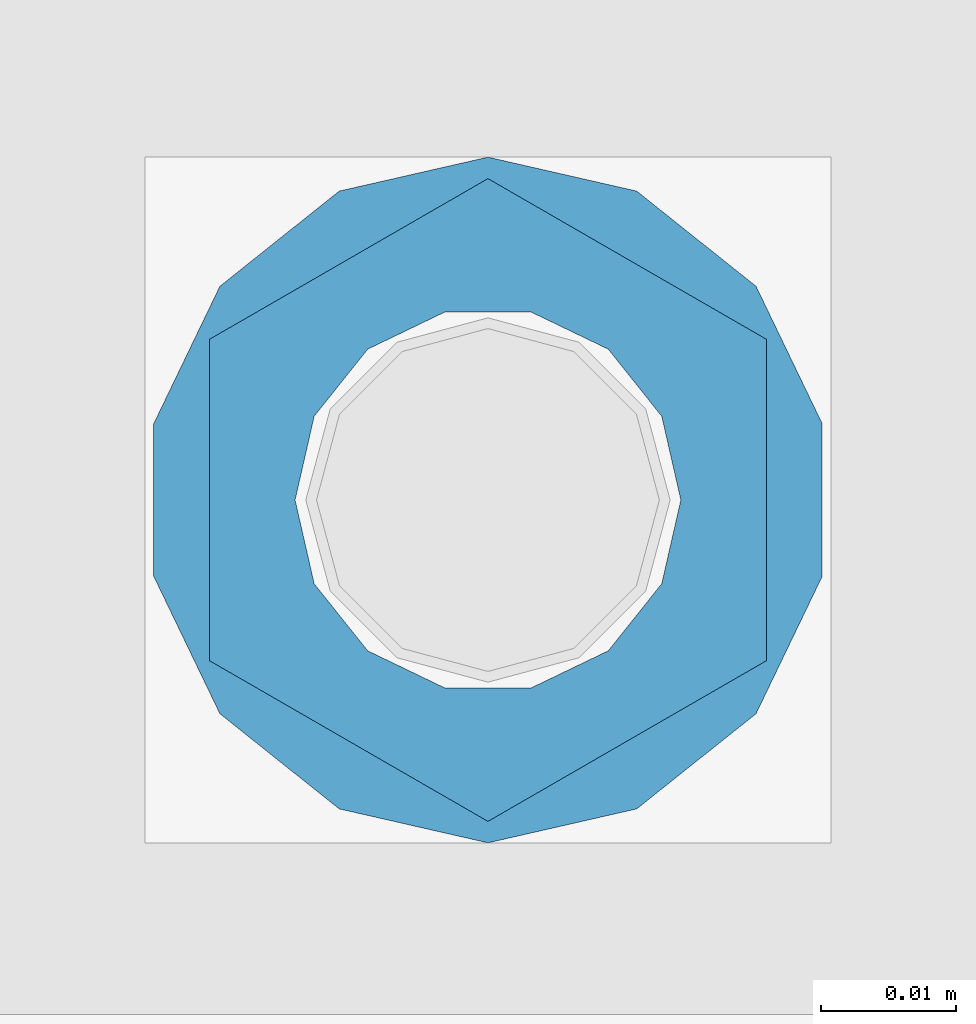
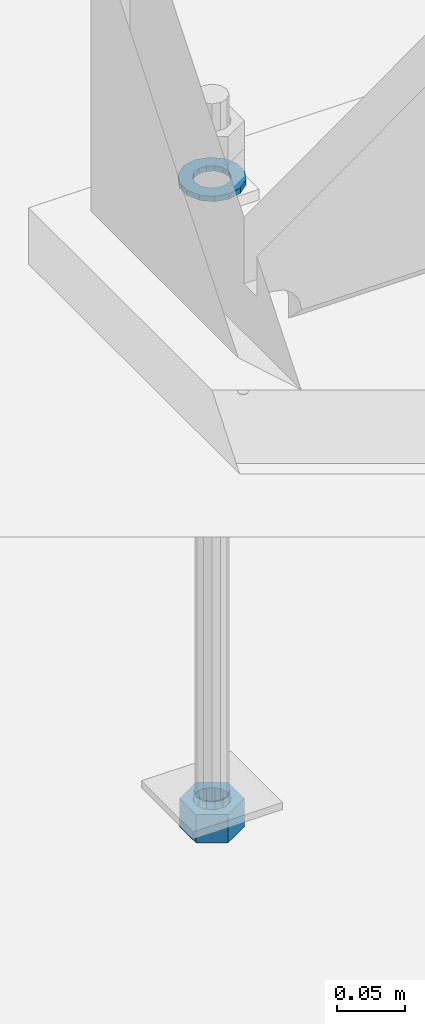
# One storey, part 1021 of 1763: 2 columns, 1 element without a shape of its own.
"""IFC2X3 building model written with IfcOpenShell, lengths in millimetres."""

from ifc_helpers import new_model, si_unit, frame, origin_with_axes, place, context, subcontext, project, spatial, faceted_brep, material, type_object, element, aggregate, save


model = new_model("IFC2X3")

# Units and contexts
model_context = context("Model", 3, precision=1e-05, world=origin_with_axes())
body_context = subcontext(model_context, "Body", "Model", "MODEL_VIEW")
ifc_project = project(units=[si_unit("LENGTHUNIT", "METRE", prefix="MILLI"), si_unit("AREAUNIT", "SQUARE_METRE"), si_unit("VOLUMEUNIT", "CUBIC_METRE"), si_unit("MASSUNIT", "GRAM", prefix="KILO"), si_unit("TIMEUNIT", "SECOND"), si_unit("PLANEANGLEUNIT", "RADIAN"), si_unit("SOLIDANGLEUNIT", "STERADIAN"), si_unit("THERMODYNAMICTEMPERATUREUNIT", "DEGREE_CELSIUS"), si_unit("LUMINOUSINTENSITYUNIT", "LUMEN")], contexts=[model_context])

# Site, building, storey
site_placement = place(None, origin_with_axes())
site = spatial("IfcSite", under=ifc_project, at=site_placement, CompositionType="ELEMENT")
building_placement = place(site_placement, origin_with_axes())
building = spatial("IfcBuilding", under=site, at=building_placement, Name="Undefined", CompositionType="ELEMENT")
storey_placement = place(building_placement, origin_with_axes())
storey = spatial("IfcBuildingStorey", under=building, at=storey_placement, Name="Undefined", CompositionType="ELEMENT", Elevation=0.0)

# Assembly, columns
assembly_placement = place(storey_placement, origin_with_axes())
assembly = element("IfcElementAssembly", 1, at=assembly_placement, inside=storey, Name="TEMPLATE", AssemblyPlace="NOTDEFINED", PredefinedType="RIGID_FRAME")
ifc_material_1 = material(Name="STEEL/A563")
column_type_1 = type_object("IfcColumnType", Name="1_HEAVY_HEX_NUT", PredefinedType="NOTDEFINED")
column_1_placement = place(assembly_placement, frame((-72745.0372736984, 52298.6, -761.999999999999), z_axis=(-1.0, 0.0, 0.0), x_axis=(0.0, 0.0, -1.0)))
column_1 = element("IfcColumn", 2, at=column_1_placement, type_object=column_type_1, material=ifc_material_1, Name="NUT", ObjectType="1_HEAVY_HEX_NUT", context=body_context, shape_type="Brep", body=[
    faceted_brep([(0.0, -23.8099994659424, 0.0), (0.0, -11.9099998474121, -20.6200008392334), (25.4, -11.9099998474121, -20.6200008392334), (25.4, -23.8099994659424, 0.0), (0.0, 11.9099998474121, -20.6200008392334), (25.4, 11.9099998474121, -20.6200008392334), (0.0, 23.8099994659424, 0.0), (25.4, 23.8099994659424, 0.0), (0.0, 11.9099998474121, 20.6200008392334), (25.4, 11.9099998474121, 20.6200008392334), (0.0, -11.9099998474121, 20.6200008392334), (25.4, -11.9099998474121, 20.6200008392334), (0.0, 0.0, 14.289999961853), (0.0, 6.20019861543551, 12.8748450879575), (25.4, 6.20019861543551, 12.8748450879502), (25.4, 0.0, 14.289999961853), (0.0, 11.1723718546418, 8.90966924477834), (25.4, 11.1723718546418, 8.90966924477834), (0.0, 13.9317198278877, 3.17982413774735), (25.4, 13.9317198278877, 3.17982413774007), (0.0, 13.9317198278877, -3.17982413774735), (25.4, 13.9317198278877, -3.17982413774007), (0.0, 11.1723718546418, -8.90966924477834), (25.4, 11.1723718546418, -8.90966924477834), (0.0, 6.20019861543551, -12.8748450879575), (25.4, 6.20019861543551, -12.8748450879502), (0.0, 0.0, -14.289999961853), (25.4, 0.0, -14.289999961853), (0.0, -6.20019861543551, -12.8748450879575), (25.4, -6.20019861543551, -12.8748450879502), (0.0, -11.1723718546418, -8.90966924477834), (25.4, -11.1723718546418, -8.90966924477834), (0.0, -13.9317198278877, -3.17982413774735), (25.4, -13.9317198278877, -3.17982413774007), (0.0, -13.9317198278877, 3.17982413774735), (25.4, -13.9317198278877, 3.17982413774007), (0.0, -11.1723718546418, 8.90966924477834), (25.4, -11.1723718546418, 8.90966924477834), (0.0, -6.20019861543551, 12.8748450879575), (25.4, -6.20019861543551, 12.8748450879502)], [[[0, 1, 2, 3]], [[1, 4, 5, 2]], [[4, 6, 7, 5]], [[6, 8, 9, 7]], [[8, 10, 11, 9]], [[10, 0, 3, 11]], [[12, 13, 14, 15]], [[13, 16, 17, 14]], [[16, 18, 19, 17]], [[18, 20, 21, 19]], [[20, 22, 23, 21]], [[22, 24, 25, 23]], [[24, 26, 27, 25]], [[26, 28, 29, 27]], [[28, 30, 31, 29]], [[30, 32, 33, 31]], [[32, 34, 35, 33]], [[34, 36, 37, 35]], [[36, 38, 39, 37]], [[38, 12, 15, 39]], [[5, 7, 9, 11, 3, 2], [17, 19, 21, 23, 25, 27, 29, 31, 33, 35, 37, 39, 15, 14]], [[10, 8, 6, 4, 1, 0], [38, 36, 34, 32, 30, 28, 26, 24, 22, 20, 18, 16, 13, 12]]]),
])
ifc_material_2 = material(Name="STEEL/F436")
column_type_2 = type_object("IfcColumnType", Name="1_WASHER", PredefinedType="NOTDEFINED")
column_2_placement = place(assembly_placement, frame((-72745.0372736984, 52298.6, -201.612499999999), z_axis=(-1.0, 0.0, 0.0), x_axis=(0.0, 0.0, -1.0)))
column_2 = element("IfcColumn", 3, at=column_2_placement, type_object=column_type_2, material=ifc_material_2, Name="WASHER", ObjectType="1_WASHER", context=body_context, shape_type="Brep", body=[
    faceted_brep([(0.0, -25.4000000000015, 0.0), (0.0, -22.8846089010258, -11.0206468080723), (4.76249999999982, -22.8846089010258, -11.0206468080723), (4.76249999999982, -25.3999996185303, 0.0), (0.0, -15.8366407293724, -19.8585193564359), (4.76249999999982, -15.8366407293724, -19.8585193564359), (0.0, -5.65203163760452, -24.7631685975066), (4.76249999999982, -5.65203163760452, -24.7631685975066), (0.0, 5.65203163760452, -24.7631685975066), (4.76249999999982, 5.65203163760452, -24.7631685975066), (0.0, 15.8366407293724, -19.8585193564359), (4.76249999999982, 15.8366407293724, -19.8585193564359), (0.0, 22.8846089010258, -11.0206468080723), (4.76249999999982, 22.8846089010258, -11.0206468080723), (0.0, 25.4000000000015, 0.0), (4.76249999999982, 25.3999996185303, 0.0), (0.0, 22.8846089010258, 11.0206468080723), (4.76249999999982, 22.8846089010258, 11.0206468080723), (0.0, 15.8366407293724, 19.8585193564359), (4.76249999999982, 15.8366407293724, 19.8585193564359), (0.0, 5.65203163760452, 24.7631685975066), (4.76249999999982, 5.65203163760452, 24.7631685975066), (0.0, -5.65203163760452, 24.7631685975066), (4.76249999999982, -5.65203163760452, 24.7631685975066), (0.0, -15.8366407293724, 19.8585193564359), (4.76249999999982, -15.8366407293724, 19.8585193564359), (0.0, -22.8846089010258, 11.0206468080723), (4.76249999999982, -22.8846089010258, 11.0206468080723), (0.0, 0.0, 14.289999961853), (0.0, 6.20019861543551, 12.8748450879575), (4.76249999999982, 6.20019861543551, 12.8748450879502), (4.76249999999982, 0.0, 14.289999961853), (0.0, 11.1723718546418, 8.90966924477834), (4.76249999999982, 11.1723718546418, 8.90966924477834), (0.0, 13.9317198278877, 3.17982413774735), (4.76249999999982, 13.9317198278877, 3.17982413774007), (0.0, 13.9317198278877, -3.17982413774735), (4.76249999999982, 13.9317198278877, -3.17982413774007), (0.0, 11.1723718546418, -8.90966924477834), (4.76249999999982, 11.1723718546418, -8.90966924477834), (0.0, 6.20019861543551, -12.8748450879575), (4.76249999999982, 6.20019861543551, -12.8748450879502), (0.0, 0.0, -14.289999961853), (4.76249999999982, 0.0, -14.289999961853), (0.0, -6.20019861543551, -12.8748450879575), (4.76249999999982, -6.20019861543551, -12.8748450879502), (0.0, -11.1723718546418, -8.90966924477834), (4.76249999999982, -11.1723718546418, -8.90966924477834), (0.0, -13.9317198278877, -3.17982413774735), (4.76249999999982, -13.9317198278877, -3.17982413774007), (0.0, -13.9317198278877, 3.17982413774735), (4.76249999999982, -13.9317198278877, 3.17982413774007), (0.0, -11.1723718546418, 8.90966924477834), (4.76249999999982, -11.1723718546418, 8.90966924477834), (0.0, -6.20019861543551, 12.8748450879575), (4.76249999999982, -6.20019861543551, 12.8748450879502)], [[[0, 1, 2, 3]], [[1, 4, 5, 2]], [[4, 6, 7, 5]], [[6, 8, 9, 7]], [[8, 10, 11, 9]], [[10, 12, 13, 11]], [[12, 14, 15, 13]], [[14, 16, 17, 15]], [[16, 18, 19, 17]], [[18, 20, 21, 19]], [[20, 22, 23, 21]], [[22, 24, 25, 23]], [[24, 26, 27, 25]], [[26, 0, 3, 27]], [[28, 29, 30, 31]], [[29, 32, 33, 30]], [[32, 34, 35, 33]], [[34, 36, 37, 35]], [[36, 38, 39, 37]], [[38, 40, 41, 39]], [[40, 42, 43, 41]], [[42, 44, 45, 43]], [[44, 46, 47, 45]], [[46, 48, 49, 47]], [[48, 50, 51, 49]], [[50, 52, 53, 51]], [[52, 54, 55, 53]], [[54, 28, 31, 55]], [[5, 7, 9, 11, 13, 15, 17, 19, 21, 23, 25, 27, 3, 2], [33, 35, 37, 39, 41, 43, 45, 47, 49, 51, 53, 55, 31, 30]], [[26, 24, 22, 20, 18, 16, 14, 12, 10, 8, 6, 4, 1, 0], [54, 52, 50, 48, 46, 44, 42, 40, 38, 36, 34, 32, 29, 28]]]),
])
aggregate(assembly, [column_2, column_1])

save(model, "model.ifc")
